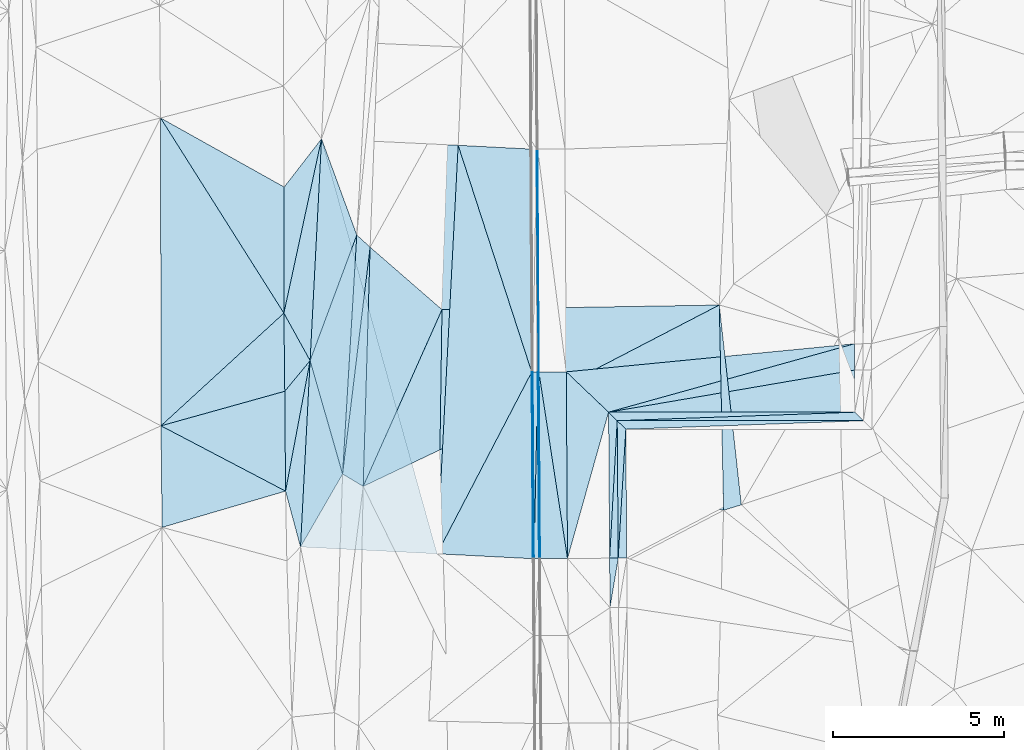
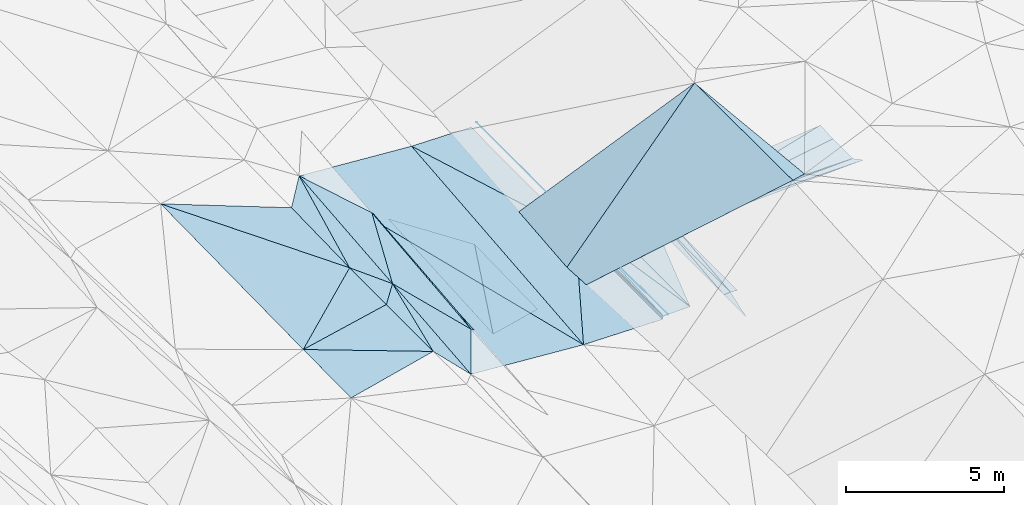
# One storey, part 93 of 275: 46 plates.
"""IFC2X3 building model written with IfcOpenShell, lengths in millimetres."""

from ifc_helpers import new_model, si_unit, frame, origin_with_axes, place, context, subcontext, project, spatial, polyline, outline, extrude, material, type_object, element, save


model = new_model("IFC2X3")

# Units and contexts
model_context = context("Model", 3, precision=1e-05, world=origin_with_axes())
body_context = subcontext(model_context, "Body", "Model", "MODEL_VIEW")
ifc_project = project(units=[si_unit("LENGTHUNIT", "METRE", prefix="MILLI"), si_unit("AREAUNIT", "SQUARE_METRE"), si_unit("VOLUMEUNIT", "CUBIC_METRE"), si_unit("MASSUNIT", "GRAM", prefix="KILO"), si_unit("TIMEUNIT", "SECOND"), si_unit("PLANEANGLEUNIT", "RADIAN"), si_unit("SOLIDANGLEUNIT", "STERADIAN"), si_unit("THERMODYNAMICTEMPERATUREUNIT", "DEGREE_CELSIUS"), si_unit("LUMINOUSINTENSITYUNIT", "LUMEN")], contexts=[model_context])

# Site, building, storey
site_placement = place(None, origin_with_axes())
site = spatial("IfcSite", under=ifc_project, at=site_placement, CompositionType="ELEMENT")
building_placement = place(site_placement, origin_with_axes())
building = spatial("IfcBuilding", under=site, at=building_placement, Name="Undefined", CompositionType="ELEMENT")
storey_placement = place(building_placement, origin_with_axes())
storey = spatial("IfcBuildingStorey", under=building, at=storey_placement, Name="Undefined", CompositionType="ELEMENT", Elevation=0.0)

# Plates
ifc_material = material()
plate_type_1 = type_object("IfcPlateType", PredefinedType="NOTDEFINED")
plate_1_placement = place(storey_placement, frame((-54754.6561920561, 44967.0363280039, 42200.3706993939), z_axis=(-0.050053988637223, 0.0171037844885867, -0.998600049458076), x_axis=(0.00717859700115731, -0.999821363627105, -0.0174845240121561)))
element("IfcPlate", 1, at=plate_1_placement, inside=storey, type_object=plate_type_1, material=ifc_material, Name="00_PR", context=body_context, shape_type="SweptSolid", body=[
    extrude(outline(polyline([(0.0, 0.0), (3767.44604492188, 6.30097929388285e-09), (3767.22729492188, 250.31266784668), (0.0, 0.0)])), frame((-8.85201319254618e-08, 2.18876761149539e-07, -0.5000001331573), z_axis=(0.0, 0.0, 1.0), x_axis=(1.0, 0.0, 0.0)), (0.0, 0.0, 1.0), 1.0),
])
plate_2_placement = place(storey_placement, frame((-54977.5969884626, 41198.4681318585, 42146.9983466235), z_axis=(-0.0335830980741986, 0.0161393565483661, -0.999305607256331), x_axis=(-0.0071784180017678, 0.999839918963378, 0.0163892270195271)))
element("IfcPlate", 2, at=plate_2_placement, inside=storey, type_object=plate_type_1, material=ifc_material, Name="00_PR", context=body_context, shape_type="SweptSolid", body=[
    extrude(outline(polyline([(0.0, 0.0), (4019.2255859375, 3.7325662560761e-09), (3767.23876953125, 250.139389038086), (0.0, 0.0)])), frame((-8.85201319254618e-08, 2.18876761149539e-07, -0.5000001331573), z_axis=(0.0, 0.0, 1.0), x_axis=(1.0, 0.0, 0.0)), (0.0, 0.0, 1.0), 1.0),
])
plate_3_placement = place(storey_placement, frame((-55006.4219450163, 45217.0504764407, 42212.8701665669), z_axis=(0.0198752310703333, 0.0165290688810968, -0.999665826700015), x_axis=(0.00717841802048257, -0.999839918963305, -0.0163892270158142)))
element("IfcPlate", 3, at=plate_3_placement, inside=storey, type_object=plate_type_1, material=ifc_material, Name="00_PR", context=body_context, shape_type="SweptSolid", body=[
    extrude(outline(polyline([(0.0, 0.0), (4019.2255859375, 3.7325662560761e-09), (4019.30688476563, 250.049514770508), (0.0, 0.0)])), frame((-8.85201319254618e-08, 2.18876761149539e-07, -0.5000001331573), z_axis=(0.0, 0.0, 1.0), x_axis=(1.0, 0.0, 0.0)), (0.0, 0.0, 1.0), 1.0),
])
plate_4_placement = place(storey_placement, frame((-55006.4256258741, 45217.0734608537, 42212.8710160335), z_axis=(0.0125132449151015, 0.0624980377927703, -0.997966639709839), x_axis=(0.999921442568018, -5.72289783641868e-05, 0.0125341699979891)))
element("IfcPlate", 4, at=plate_4_placement, inside=storey, type_object=plate_type_1, material=ifc_material, Name="00_PR", context=body_context, shape_type="SweptSolid", body=[
    extrude(outline(polyline([(0.0, 0.0), (7201.75341796875, -2.31520971283317e-08), (251.638565063477, 250.489715576172), (0.0, 0.0)])), frame((-8.85201319254618e-08, 2.18876761149539e-07, -0.5000001331573), z_axis=(0.0, 0.0, 1.0), x_axis=(1.0, 0.0, 0.0)), (0.0, 0.0, 1.0), 1.0),
])
plate_5_placement = place(storey_placement, frame((-48057.0388273613, 45466.6408138682, 42298.1380522502), z_axis=(0.0125334070268612, -0.0073737759030965, -0.999894264978668), x_axis=(0.709548887107373, -0.704515339074986, 0.0140894929910481)))
element("IfcPlate", 5, at=plate_5_placement, inside=storey, type_object=plate_type_1, material=ifc_material, Name="00_PR", context=body_context, shape_type="SweptSolid", body=[
    extrude(outline(polyline([(0.0, 0.0), (354.874359130859, -1.2801137927454e-10), (-4756.2822265625, 5073.59130859375), (0.0, 0.0)])), frame((-8.85201319254618e-08, 2.18876761149539e-07, -0.5000001331573), z_axis=(0.0, 0.0, 1.0), x_axis=(1.0, 0.0, 0.0)), (0.0, 0.0, 1.0), 1.0),
])
plate_6_placement = place(storey_placement, frame((-55217.1639350213, 39748.2080350099, 42122.2991473268), z_axis=(0.0198960001570522, 0.013738804213122, -0.999707654485322), x_axis=(-0.00717939200616372, 0.999881764103199, 0.0135983140240582)))
element("IfcPlate", 6, at=plate_6_placement, inside=storey, type_object=plate_type_1, material=ifc_material, Name="00_PR", context=body_context, shape_type="SweptSolid", body=[
    extrude(outline(polyline([(0.0, 0.0), (1448.63586425781, 2.10275175049901e-09), (1448.70336914063, 250.049514770508), (0.0, 0.0)])), frame((-8.85201319254618e-08, 2.18876761149539e-07, -0.5000001331573), z_axis=(0.0, 0.0, 1.0), x_axis=(1.0, 0.0, 0.0)), (0.0, 0.0, 1.0), 1.0),
])
plate_7_placement = place(storey_placement, frame((-55258.227644883, 45467.0534748413, 42207.8700538032), z_axis=(0.0125334070268612, -0.0073737759030965, -0.999894264978668), x_axis=(0.999921442568018, -5.72289783641868e-05, 0.0125341699979891)))
element("IfcPlate", 7, at=plate_7_placement, inside=storey, type_object=plate_type_1, material=ifc_material, Name="00_PR", context=body_context, shape_type="SweptSolid", body=[
    extrude(outline(polyline([(0.0, 0.0), (7201.75439453125, 1.70766725204885e-08), (251.859252929688, 250.007308959961), (0.0, 0.0)])), frame((-8.85201319254618e-08, 2.18876761149539e-07, -0.5000001331573), z_axis=(0.0, 0.0, 1.0), x_axis=(1.0, 0.0, 0.0)), (0.0, 0.0, 1.0), 1.0),
])
plate_8_placement = place(storey_placement, frame((-55227.555591409, 41196.6735691613, 42141.9983757898), z_axis=(0.0353986654577949, 0.0156678779979407, -0.999250445125169), x_axis=(-0.0071787759749593, 0.999855286850542, 0.0154230519846361)))
element("IfcPlate", 8, at=plate_8_placement, inside=storey, type_object=plate_type_1, material=ifc_material, Name="00_PR", context=body_context, shape_type="SweptSolid", body=[
    extrude(outline(polyline([(0.0, 0.0), (4271.00927734375, -1.06738298200071e-08), (4019.30029296875, 250.158294677734), (0.0, 0.0)])), frame((-8.85201319254618e-08, 2.18876761149539e-07, -0.5000001331573), z_axis=(0.0, 0.0, 1.0), x_axis=(1.0, 0.0, 0.0)), (0.0, 0.0, 1.0), 1.0),
])
plate_type_2 = type_object("IfcPlateType", PredefinedType="NOTDEFINED")
plate_9_placement = place(storey_placement, frame((-60131.2364615722, 48467.1082151592, 41398.51102448), z_axis=(-0.208831258783184, 0.00492731227025753, -0.977939275696003), x_axis=(-0.0144608824656281, -0.999893534677639, -0.00194992004242631)))
element("IfcPlate", 9, at=plate_9_placement, inside=storey, type_object=plate_type_2, material=ifc_material, Name="00", context=body_context, shape_type="SweptSolid", body=[
    extrude(outline(polyline([(0.0, 0.0), (4102.73291015625, 6.28642737865448e-09), (5202.06005859375, 2279.5048828125), (0.0, 0.0)])), frame((-8.85201319254618e-08, 2.18876761149539e-07, -0.5000001331573), z_axis=(0.0, 0.0, 1.0), x_axis=(1.0, 0.0, 0.0)), (0.0, 0.0, 1.0), 1.0),
])
plate_type_3 = type_object("IfcPlateType", PredefinedType="NOTDEFINED")
plate_10_placement = place(storey_placement, frame((-60273.6242718858, 41325.1492362148, 41896.5693542058), z_axis=(-0.0322864705022695, 0.019242341184966, -0.999293408428289), x_axis=(-0.998195226832826, 0.0500309300157187, 0.0332143819741704)))
element("IfcPlate", 10, at=plate_10_placement, inside=storey, type_object=plate_type_3, material=ifc_material, Name="00_PR", context=body_context, shape_type="SweptSolid", body=[
    extrude(outline(polyline([(0.0, 0.0), (4002.2119140625, -2.02999217435718e-09), (3992.19409179688, 11955.9609375), (0.0, 0.0)])), frame((-8.85201319254618e-08, 2.18876761149539e-07, -0.5000001331573), z_axis=(0.0, 0.0, 1.0), x_axis=(1.0, 0.0, 0.0)), (0.0, 0.0, 1.0), 1.0),
])
plate_type_4 = type_object("IfcPlateType", PredefinedType="NOTDEFINED")
plate_11_placement = place(storey_placement, frame((-57505.9185339254, 46640.2107482586, 42065.3517347379), z_axis=(0.970089214317012, 0.0102205203270063, -0.242533414667025), x_axis=(0.242518705990443, 0.00267351302670711, 0.970143045933339)))
element("IfcPlate", 11, at=plate_11_placement, inside=storey, type_object=plate_type_4, material=ifc_material, Name="00_PR", context=body_context, shape_type="SweptSolid", body=[
    extrude(outline(polyline([(0.0, 0.0), (123.693099975586, 3.20142135024071e-10), (36.241886138916, 5459.546875), (0.0, 0.0)])), frame((-8.85201319254618e-08, 2.18876761149539e-07, -0.5000001331573), z_axis=(0.0, 0.0, 1.0), x_axis=(1.0, 0.0, 0.0)), (0.0, 0.0, 1.0), 1.0),
])
plate_12_placement = place(storey_placement, frame((-57439.4557299682, 41181.0656523603, 42101.1387341122), z_axis=(0.970088817603844, 0.0102205056216197, -0.242535002061175), x_axis=(-0.242514674954377, -0.00320214202672689, -0.970142452796605)))
element("IfcPlate", 12, at=plate_12_placement, inside=storey, type_object=plate_type_4, material=ifc_material, Name="00_PR", context=body_context, shape_type="SweptSolid", body=[
    extrude(outline(polyline([(0.0, 0.0), (123.693176269531, -2.18278728425503e-11), (33.3557357788086, 5459.56494140625), (0.0, 0.0)])), frame((-8.85201319254618e-08, 2.18876761149539e-07, -0.5000001331573), z_axis=(0.0, 0.0, 1.0), x_axis=(1.0, 0.0, 0.0)), (0.0, 0.0, 1.0), 1.0),
])
plate_type_5 = type_object("IfcPlateType", PredefinedType="NOTDEFINED")
plate_13_placement = place(storey_placement, frame((-57439.9408222537, 41181.0682522599, 42100.7600627762), z_axis=(-9.13452244903414e-05, 0.0154229424386856, -0.999881055177356), x_axis=(0.0207857459866335, 0.999665067370755, 0.0154177119704065)))
element("IfcPlate", 13, at=plate_13_placement, inside=storey, type_object=plate_type_5, material=ifc_material, Name="00_PR", context=body_context, shape_type="SweptSolid", body=[
    extrude(outline(polyline([(0.0, 0.0), (5462.0947265625, 1.3526005204767e-08), (4.00590229034424, 149.946624755859), (0.0, 0.0)])), frame((-8.85201319254618e-08, 2.18876761149539e-07, -0.5000001331573), z_axis=(0.0, 0.0, 1.0), x_axis=(1.0, 0.0, 0.0)), (0.0, 0.0, 1.0), 1.0),
])
plate_14_placement = place(storey_placement, frame((-57326.4071096397, 46641.3334336562, 42184.9730626691), z_axis=(-8.11642197370288e-05, 0.0154227308238677, -0.999881059319709), x_axis=(-0.0207857459545196, -0.999665067371238, -0.0154177119823899)))
element("IfcPlate", 14, at=plate_14_placement, inside=storey, type_object=plate_type_5, material=ifc_material, Name="00_PR", context=body_context, shape_type="SweptSolid", body=[
    extrude(outline(polyline([(0.0, 0.0), (5462.0947265625, 1.3526005204767e-08), (3.90695929527283, 149.949813842773), (0.0, 0.0)])), frame((-8.85201319254618e-08, 2.18876761149539e-07, -0.5000001331573), z_axis=(0.0, 0.0, 1.0), x_axis=(1.0, 0.0, 0.0)), (0.0, 0.0, 1.0), 1.0),
])
plate_type_6 = type_object("IfcPlateType", PredefinedType="NOTDEFINED")
plate_15_placement = place(storey_placement, frame((-57333.3932535563, 53156.9671595904, 42286.7951616364), z_axis=(0.0199137889874449, 0.0156437858381664, -0.999679305063786), x_axis=(0.00567731103244658, -0.999863228802806, -0.0155335709824878)))
element("IfcPlate", 15, at=plate_15_placement, inside=storey, type_object=plate_type_6, material=ifc_material, Name="00_PR", context=body_context, shape_type="SweptSolid", body=[
    extrude(outline(polyline([(0.0, 0.0), (6516.337890625, -1.64873199537396e-08), (-0.00770944636315107, 30.0061664581299), (0.0, 0.0)])), frame((-8.85201319254618e-08, 2.18876761149539e-07, -0.5000001331573), z_axis=(0.0, 0.0, 1.0), x_axis=(1.0, 0.0, 0.0)), (0.0, 0.0, 1.0), 1.0),
])
plate_16_placement = place(storey_placement, frame((-57296.3979936511, 46641.5204184766, 42185.5731607943), z_axis=(0.0198831661735067, 0.0155533504782911, -0.999681325719259), x_axis=(0.00667819302977025, -0.999858752033622, -0.0154232849816642)))
element("IfcPlate", 16, at=plate_16_placement, inside=storey, type_object=plate_type_6, material=ifc_material, Name="00_PR", context=body_context, shape_type="SweptSolid", body=[
    extrude(outline(polyline([(0.0, 0.0), (5460.12060546875, 1.83354131877422e-08), (5460.14404296875, 30.0058403015137), (0.0, 0.0)])), frame((-8.85201319254618e-08, 2.18876761149539e-07, -0.5000001331573), z_axis=(0.0, 0.0, 1.0), x_axis=(1.0, 0.0, 0.0)), (0.0, 0.0, 1.0), 1.0),
])
plate_17_placement = place(storey_placement, frame((-57289.9333338589, 41181.9567086389, 42100.7601628065), z_axis=(0.0198972894556554, 0.0155533629643728, -0.999681044520109), x_axis=(-0.0066781930210375, 0.999858752033822, 0.0154232849724548)))
element("IfcPlate", 17, at=plate_17_placement, inside=storey, type_object=plate_type_6, material=ifc_material, Name="00_PR", context=body_context, shape_type="SweptSolid", body=[
    extrude(outline(polyline([(0.0, 0.0), (5460.14794921875, -1.5905243344605e-08), (5460.14404296875, 30.0057125091553), (0.0, 0.0)])), frame((-8.85201319254618e-08, 2.18876761149539e-07, -0.5000001331573), z_axis=(0.0, 0.0, 1.0), x_axis=(1.0, 0.0, 0.0)), (0.0, 0.0, 1.0), 1.0),
])
plate_type_7 = type_object("IfcPlateType", PredefinedType="NOTDEFINED")
plate_18_placement = place(storey_placement, frame((-63653.2273203775, 53463.653851786, 42239.5003682818), z_axis=(-0.0333468863461825, 0.0189462760226475, -0.999264241227459), x_axis=(0.998268639349457, -0.0478400050471519, -0.0342207189940953)))
element("IfcPlate", 18, at=plate_18_placement, inside=storey, type_object=plate_type_7, material=ifc_material, Name="00_PR", context=body_context, shape_type="SweptSolid", body=[
    extrude(outline(polyline([(0.0, 0.0), (4002.37060546875, -7.55971996113658e-09), (3966.19262695313, 11964.611328125), (0.0, 0.0)])), frame((-8.85201319254618e-08, 2.18876761149539e-07, -0.5000001331573), z_axis=(0.0, 0.0, 1.0), x_axis=(1.0, 0.0, 0.0)), (0.0, 0.0, 1.0), 1.0),
])
plate_type_8 = type_object("IfcPlateType", PredefinedType="NOTDEFINED")
plate_19_placement = place(storey_placement, frame((-48071.4047826636, 47466.6370522363, 42382.0769789326), z_axis=(-0.00058007674561187, 0.0888629904230633, -0.996043690027722), x_axis=(0.00715078199816748, -0.996018022971129, -0.0888648650114254)))
element("IfcPlate", 19, at=plate_19_placement, inside=storey, type_object=plate_type_8, material=ifc_material, Name="00_PR", context=body_context, shape_type="SweptSolid", body=[
    extrude(outline(polyline([(0.0, 0.0), (770.709533691406, -1.50612322613597e-09), (1955.66259765625, 7200.9990234375), (0.0, 0.0)])), frame((-8.85201319254618e-08, 2.18876761149539e-07, -0.5000001331573), z_axis=(0.0, 0.0, 1.0), x_axis=(1.0, 0.0, 0.0)), (0.0, 0.0, 1.0), 1.0),
])
plate_type_9 = type_object("IfcPlateType", PredefinedType="NOTDEFINED")
plate_20_placement = place(storey_placement, frame((-48065.8870492746, 46698.9583307277, 42313.5860800238), z_axis=(0.0125338923302833, 0.0126238441954289, -0.999841757530052), x_axis=(0.00717946097368381, -0.999895665081337, -0.0125345239908739)))
element("IfcPlate", 20, at=plate_20_placement, inside=storey, type_object=plate_type_9, material=ifc_material, Name="00_PR", context=body_context, shape_type="SweptSolid", body=[
    extrude(outline(polyline([(0.0, 0.0), (1232.43615722656, -4.04543243348598e-09), (1181.45434570313, 7201.57421875), (0.0, 0.0)])), frame((-8.85201319254618e-08, 2.18876761149539e-07, -0.5000001331573), z_axis=(0.0, 0.0, 1.0), x_axis=(1.0, 0.0, 0.0)), (0.0, 0.0, 1.0), 1.0),
])
plate_type_10 = type_object("IfcPlateType", PredefinedType="NOTDEFINED")
plate_21_placement = place(storey_placement, frame((-55258.2239739732, 45467.0649431578, 42207.8701604175), z_axis=(0.019903297863113, 0.015557512476293, -0.999680860344801), x_axis=(-0.724072856799147, 0.689713663845179, -0.00368238400789)))
element("IfcPlate", 21, at=plate_21_placement, inside=storey, type_object=plate_type_10, material=ifc_material, Name="00_PR", context=body_context, shape_type="SweptSolid", body=[
    extrude(outline(polyline([(0.0, 0.0), (1710.03344726563, -1.67710823006928e-09), (-3825.32275390625, 6406.70849609375), (0.0, 0.0)])), frame((-8.85201319254618e-08, 2.18876761149539e-07, -0.5000001331573), z_axis=(0.0, 0.0, 1.0), x_axis=(1.0, 0.0, 0.0)), (0.0, 0.0, 1.0), 1.0),
])
plate_type_11 = type_object("IfcPlateType", PredefinedType="NOTDEFINED")
plate_22_placement = place(storey_placement, frame((-56496.4127879231, 46646.4983941484, 42201.5731610095), z_axis=(0.019897195094357, 0.0155555039090625, -0.999681013086431), x_axis=(0.00667821399454487, -0.99985872005324, -0.0154253489860309)))
element("IfcPlate", 22, at=plate_22_placement, inside=storey, type_object=plate_type_11, material=ifc_material, Name="00_PR", context=body_context, shape_type="SweptSolid", body=[
    extrude(outline(polyline([(0.0, 0.0), (5459.39013671875, -1.72440195456147e-08), (-0.118396855890751, 800.16064453125), (0.0, 0.0)])), frame((-8.85201319254618e-08, 2.18876761149539e-07, -0.5000001331573), z_axis=(0.0, 0.0, 1.0), x_axis=(1.0, 0.0, 0.0)), (0.0, 0.0, 1.0), 1.0),
])
plate_23_placement = place(storey_placement, frame((-57259.9342531593, 41182.1709404201, 42101.3601609169), z_axis=(0.0198831661735067, 0.0155533504782911, -0.999681325719259), x_axis=(-0.0066781930210375, 0.999858752033822, 0.0154232849724548)))
element("IfcPlate", 23, at=plate_23_placement, inside=storey, type_object=plate_type_11, material=ifc_material, Name="00_PR", context=body_context, shape_type="SweptSolid", body=[
    extrude(outline(polyline([(0.0, 0.0), (5460.12060546875, 1.83354131877422e-08), (0.611967802047729, 800.160522460938), (0.0, 0.0)])), frame((-8.85201319254618e-08, 2.18876761149539e-07, -0.5000001331573), z_axis=(0.0, 0.0, 1.0), x_axis=(1.0, 0.0, 0.0)), (0.0, 0.0, 1.0), 1.0),
])
plate_type_12 = type_object("IfcPlateType", PredefinedType="NOTDEFINED")
plate_24_placement = place(storey_placement, frame((-56459.9538061074, 41187.8793675708, 42117.3601610179), z_axis=(0.0199014105104961, 0.0155555307619156, -0.999680928757975), x_axis=(-0.00667821399304553, 0.999858720053274, 0.0154253489844649)))
element("IfcPlate", 24, at=plate_24_placement, inside=storey, type_object=plate_type_12, material=ifc_material, Name="00_PR", context=body_context, shape_type="SweptSolid", body=[
    extrude(outline(polyline([(0.0, 0.0), (5459.39013671875, -1.72440195456147e-08), (4271.95166015625, 1230.53002929688), (0.0, 0.0)])), frame((-8.85201319254618e-08, 2.18876761149539e-07, -0.5000001331573), z_axis=(0.0, 0.0, 1.0), x_axis=(1.0, 0.0, 0.0)), (0.0, 0.0, 1.0), 1.0),
])
plate_type_13 = type_object("IfcPlateType", PredefinedType="NOTDEFINED")
plate_25_placement = place(storey_placement, frame((-59657.754018102, 53272.1788114362, 42102.5363037553), z_axis=(0.0310161038302799, 0.0157219267080249, -0.999395228287476), x_axis=(0.998218742855814, -0.0514695879700982, 0.0301699009866757)))
element("IfcPlate", 25, at=plate_25_placement, inside=storey, type_object=plate_type_13, material=ifc_material, Name="00_PR", context=body_context, shape_type="SweptSolid", body=[
    extrude(outline(polyline([(0.0, 0.0), (2118.1044921875, -6.38829078525305e-09), (2487.7451171875, 6513.361328125), (0.0, 0.0)])), frame((-8.85201319254618e-08, 2.18876761149539e-07, -0.5000001331573), z_axis=(0.0, 0.0, 1.0), x_axis=(1.0, 0.0, 0.0)), (0.0, 0.0, 1.0), 1.0),
])
plate_type_14 = type_object("IfcPlateType", PredefinedType="NOTDEFINED")
plate_26_placement = place(storey_placement, frame((-57506.3881912908, 46640.2134596803, 42064.9732996112), z_axis=(0.0307739461009114, 0.015643421975049, -0.999403946155051), x_axis=(-0.461613138973683, -0.886636410996624, -0.0280924299748123)))
element("IfcPlate", 26, at=plate_26_placement, inside=storey, type_object=plate_type_14, material=ifc_material, Name="00_PR", context=body_context, shape_type="SweptSolid", body=[
    extrude(outline(polyline([(0.0, 0.0), (5994.64013671875, -1.00699253380299e-08), (-4888.09814453125, 4971.84521484375), (0.0, 0.0)])), frame((-8.85201319254618e-08, 2.18876761149539e-07, -0.5000001331573), z_axis=(0.0, 0.0, 1.0), x_axis=(1.0, 0.0, 0.0)), (0.0, 0.0, 1.0), 1.0),
])
plate_type_15 = type_object("IfcPlateType", PredefinedType="NOTDEFINED")
plate_27_placement = place(storey_placement, frame((-60273.5927210615, 41325.1474282784, 41896.5693001057), z_axis=(0.0308159180927162, 0.0156215397920913, -0.99940299513591), x_axis=(0.461613138971989, 0.886636410997533, 0.0280924299739359)))
element("IfcPlate", 27, at=plate_27_placement, inside=storey, type_object=plate_type_15, material=ifc_material, Name="00_PR", context=body_context, shape_type="SweptSolid", body=[
    extrude(outline(polyline([(0.0, 0.0), (5994.64013671875, -1.00699253380299e-08), (1168.47912597656, 2554.05224609375), (0.0, 0.0)])), frame((-8.85201319254618e-08, 2.18876761149539e-07, -0.5000001331573), z_axis=(0.0, 0.0, 1.0), x_axis=(1.0, 0.0, 0.0)), (0.0, 0.0, 1.0), 1.0),
])
plate_type_16 = type_object("IfcPlateType", PredefinedType="NOTDEFINED")
plate_28_placement = place(storey_placement, frame((-63987.8271258391, 46974.2046263685, 42129.5001655714), z_axis=(-0.0205081433501414, 0.0169567398640997, -0.999645879814203), x_axis=(-0.184939913394449, -0.982665494161713, -0.0128745880543849)))
element("IfcPlate", 28, at=plate_28_placement, inside=storey, type_object=plate_type_16, material=ifc_material, Name="00", context=body_context, shape_type="SweptSolid", body=[
    extrude(outline(polyline([(0.0, 0.0), (3883.61938476563, -4.8748916015029e-09), (1017.607421875, 562.561218261719), (0.0, 0.0)])), frame((-8.85201319254618e-08, 2.18876761149539e-07, -0.5000001331573), z_axis=(0.0, 0.0, 1.0), x_axis=(1.0, 0.0, 0.0)), (0.0, 0.0, 1.0), 1.0),
])
plate_type_17 = type_object("IfcPlateType", PredefinedType="NOTDEFINED")
plate_29_placement = place(storey_placement, frame((-63653.2293928129, 53463.6552904736, 42239.5004547855), z_axis=(-0.0372834350168629, 0.0217611188936698, -0.999067765057926), x_axis=(-0.211057515330362, -0.977381619847664, -0.0134124720514585)))
element("IfcPlate", 29, at=plate_29_placement, inside=storey, type_object=plate_type_17, material=ifc_material, Name="00", context=body_context, shape_type="SweptSolid", body=[
    extrude(outline(polyline([(0.0, 0.0), (5219.02294921875, -1.6778358258307e-08), (1610.68469238281, 770.191528320313), (0.0, 0.0)])), frame((-8.85201319254618e-08, 2.18876761149539e-07, -0.5000001331573), z_axis=(0.0, 0.0, 1.0), x_axis=(1.0, 0.0, 0.0)), (0.0, 0.0, 1.0), 1.0),
])
plate_type_18 = type_object("IfcPlateType", PredefinedType="NOTDEFINED")
plate_30_placement = place(storey_placement, frame((-60131.2600685729, 48467.1192607718, 41398.5168505013), z_axis=(-0.256044144124866, 0.0270191226725977, -0.966287412351712), x_axis=(-0.405704359347007, -0.910314249796572, 0.0820483968407598)))
element("IfcPlate", 30, at=plate_30_placement, inside=storey, type_object=plate_type_18, material=ifc_material, Name="00", context=body_context, shape_type="SweptSolid", body=[
    extrude(outline(polyline([(0.0, 0.0), (5679.57470703125, -1.23691279441118e-08), (-759.683654785156, 2746.78002929688), (0.0, 0.0)])), frame((-8.85201319254618e-08, 2.18876761149539e-07, -0.5000001331573), z_axis=(0.0, 0.0, 1.0), x_axis=(1.0, 0.0, 0.0)), (0.0, 0.0, 1.0), 1.0),
])
plate_type_19 = type_object("IfcPlateType", PredefinedType="NOTDEFINED")
plate_31_placement = place(storey_placement, frame((-62622.6891740049, 50647.8969159883, 42160.5001954463), z_axis=(-0.0229115930090386, 0.0169488664964395, -0.999593814921978), x_axis=(-0.0592883314823341, -0.998119545343259, -0.0155649270415063)))
element("IfcPlate", 31, at=plate_31_placement, inside=storey, type_object=plate_type_19, material=ifc_material, Name="00", context=body_context, shape_type="SweptSolid", body=[
    extrude(outline(polyline([(0.0, 0.0), (7002.923828125, 1.04773789644241e-09), (3748.20336914063, 1145.23010253906), (0.0, 0.0)])), frame((-8.85201319254618e-08, 2.18876761149539e-07, -0.5000001331573), z_axis=(0.0, 0.0, 1.0), x_axis=(1.0, 0.0, 0.0)), (0.0, 0.0, 1.0), 1.0),
])
plate_type_20 = type_object("IfcPlateType", PredefinedType="NOTDEFINED")
plate_32_placement = place(storey_placement, frame((-63653.2240459974, 53463.6535640847, 42239.5002529894), z_axis=(-0.0265837321675006, 0.0183124588276819, -0.999478843715929), x_axis=(0.34357360547505, -0.938756347741967, -0.0263381319580016)))
element("IfcPlate", 32, at=plate_32_placement, inside=storey, type_object=plate_type_20, material=ifc_material, Name="00", context=body_context, shape_type="SweptSolid", body=[
    extrude(outline(polyline([(0.0, 0.0), (2999.45336914063, 6.9339876063168e-09), (5979.9462890625, 2545.04321289063), (0.0, 0.0)])), frame((-8.85201319254618e-08, 2.18876761149539e-07, -0.5000001331573), z_axis=(0.0, 0.0, 1.0), x_axis=(1.0, 0.0, 0.0)), (0.0, 0.0, 1.0), 1.0),
])
plate_type_21 = type_object("IfcPlateType", PredefinedType="NOTDEFINED")
plate_33_placement = place(storey_placement, frame((-63987.8360630767, 46974.2063044668, 42129.5004601719), z_axis=(-0.0383834512540743, 0.0203131928575153, -0.999056597428674), x_axis=(-0.0514535353943072, -0.998507246322793, -0.0183251940316938)))
element("IfcPlate", 33, at=plate_33_placement, inside=storey, type_object=plate_type_21, material=ifc_material, Name="00", context=body_context, shape_type="SweptSolid", body=[
    extrude(outline(polyline([(0.0, 0.0), (5456.96826171875, -1.17870513349772e-08), (3848.47412109375, 521.293823242188), (0.0, 0.0)])), frame((-8.85201319254618e-08, 2.18876761149539e-07, -0.5000001331573), z_axis=(0.0, 0.0, 1.0), x_axis=(1.0, 0.0, 0.0)), (0.0, 0.0, 1.0), 1.0),
])
plate_type_22 = type_object("IfcPlateType", PredefinedType="NOTDEFINED")
plate_34_placement = place(storey_placement, frame((-63653.2205657407, 53463.653388336, 42239.500165661), z_axis=(-0.0196288233764554, 0.0179566870940788, -0.999646070707759), x_axis=(-0.0514857863485739, -0.998530287535762, -0.0169256810149085)))
element("IfcPlate", 34, at=plate_34_placement, inside=storey, type_object=plate_type_22, material=ifc_material, Name="00", context=body_context, shape_type="SweptSolid", body=[
    extrude(outline(polyline([(0.0, 0.0), (6499.0, -1.68656697496772e-08), (5151.376953125, 837.563720703125), (0.0, 0.0)])), frame((-8.85201319254618e-08, 2.18876761149539e-07, -0.5000001331573), z_axis=(0.0, 0.0, 1.0), x_axis=(1.0, 0.0, 0.0)), (0.0, 0.0, 1.0), 1.0),
])
plate_type_23 = type_object("IfcPlateType", PredefinedType="NOTDEFINED")
plate_35_placement = place(storey_placement, frame((-63987.8245251216, 46974.2057128975, 42129.5001395064), z_axis=(-0.0152891869231709, 0.0191349432157854, -0.999700002356385), x_axis=(0.275320995630337, -0.961086517006396, -0.0226065520067723)))
element("IfcPlate", 35, at=plate_35_placement, inside=storey, type_object=plate_type_23, material=ifc_material, Name="00", context=body_context, shape_type="SweptSolid", body=[
    extrude(outline(polyline([(0.0, 0.0), (3450.3271484375, -1.18961906991899e-08), (5161.74560546875, 1770.56042480469), (0.0, 0.0)])), frame((-8.85201319254618e-08, 2.18876761149539e-07, -0.5000001331573), z_axis=(0.0, 0.0, 1.0), x_axis=(1.0, 0.0, 0.0)), (0.0, 0.0, 1.0), 1.0),
])
plate_type_24 = type_object("IfcPlateType", PredefinedType="NOTDEFINED")
plate_36_placement = place(storey_placement, frame((-64728.7713317367, 46078.0915826198, 42129.5005311303), z_axis=(-0.0433672680436388, 0.0169965782397606, -0.998914609158646), x_axis=(-0.962539503708967, -0.26857495356385, 0.0372182497959095)))
element("IfcPlate", 36, at=plate_36_placement, inside=storey, type_object=plate_type_24, material=ifc_material, Name="00", context=body_context, shape_type="SweptSolid", body=[
    extrude(outline(polyline([(0.0, 0.0), (3761.59545898438, 7.07950675860047e-09), (-587.09130859375, 2208.37573242188), (0.0, 0.0)])), frame((-8.85201319254618e-08, 2.18876761149539e-07, -0.5000001331573), z_axis=(0.0, 0.0, 1.0), x_axis=(1.0, 0.0, 0.0)), (0.0, 0.0, 1.0), 1.0),
])
plate_type_25 = type_object("IfcPlateType", PredefinedType="NOTDEFINED")
plate_37_placement = place(storey_placement, frame((-62435.500855635, 43296.9217631434, 41864.5203602649), z_axis=(-0.281174911596404, 0.0276034603930396, -0.959259463369053), x_axis=(-0.828807092118039, 0.49689892246479, 0.257235815757003)))
element("IfcPlate", 37, at=plate_37_placement, inside=storey, type_object=plate_type_25, material=ifc_material, Name="00", context=body_context, shape_type="SweptSolid", body=[
    extrude(outline(polyline([(0.0, 0.0), (726.959411621094, 4.02906152885407e-10), (3345.22387695313, 6149.66064453125), (0.0, 0.0)])), frame((-8.85201319254618e-08, 2.18876761149539e-07, -0.5000001331573), z_axis=(0.0, 0.0, 1.0), x_axis=(1.0, 0.0, 0.0)), (0.0, 0.0, 1.0), 1.0),
])
plate_type_26 = type_object("IfcPlateType", PredefinedType="NOTDEFINED")
plate_38_placement = place(storey_placement, frame((-51894.8121510542, 42598.2783111021, 44540.5012870117), z_axis=(-0.067377152556517, 0.0253386470772251, -0.997405771127113), x_axis=(-0.0209611686243008, 0.999420871096889, 0.0268058170149608)))
element("IfcPlate", 38, at=plate_38_placement, inside=storey, type_object=plate_type_26, material=ifc_material, Name="00", context=body_context, shape_type="SweptSolid", body=[
    extrude(outline(polyline([(0.0, 0.0), (6006.1591796875, 2.17114575207233e-08), (147.607315063477, 523.24951171875), (0.0, 0.0)])), frame((-8.85201319254618e-08, 2.18876761149539e-07, -0.5000001331573), z_axis=(0.0, 0.0, 1.0), x_axis=(1.0, 0.0, 0.0)), (0.0, 0.0, 1.0), 1.0),
])
plate_type_27 = type_object("IfcPlateType", PredefinedType="NOTDEFINED")
plate_39_placement = place(storey_placement, frame((-64754.7449201978, 48362.6782399519, 42169.5005137427), z_axis=(-0.0403294043656748, 0.0217662077983493, -0.99894933372098), x_axis=(-0.533632048311866, 0.844772627312639, 0.0399505338860799)))
element("IfcPlate", 39, at=plate_39_placement, inside=storey, type_object=plate_type_27, material=ifc_material, Name="00", context=body_context, shape_type="SweptSolid", body=[
    extrude(outline(polyline([(0.0, 0.0), (6758.35791015625, 4.91127138957381e-09), (3114.39575195313, 1978.34265136719), (0.0, 0.0)])), frame((-8.85201319254618e-08, 2.18876761149539e-07, -0.5000001331573), z_axis=(0.0, 0.0, 1.0), x_axis=(1.0, 0.0, 0.0)), (0.0, 0.0, 1.0), 1.0),
])
plate_type_28 = type_object("IfcPlateType", PredefinedType="NOTDEFINED")
plate_40_placement = place(storey_placement, frame((-64754.7351957889, 48362.6759893882, 42169.5001718844), z_axis=(-0.0208807477785945, 0.0172648200048166, -0.999632892797355), x_axis=(0.483336772507556, -0.875071447624611, -0.0252096389134645)))
element("IfcPlate", 40, at=plate_40_placement, inside=storey, type_object=plate_type_28, material=ifc_material, Name="00", context=body_context, shape_type="SweptSolid", body=[
    extrude(outline(polyline([(0.0, 0.0), (1586.69470214844, 2.8521753847599e-09), (2012.73754882813, 1081.890625), (0.0, 0.0)])), frame((-8.85201319254618e-08, 2.18876761149539e-07, -0.5000001331573), z_axis=(0.0, 0.0, 1.0), x_axis=(1.0, 0.0, 0.0)), (0.0, 0.0, 1.0), 1.0),
])
plate_type_29 = type_object("IfcPlateType", PredefinedType="NOTDEFINED")
plate_41_placement = place(storey_placement, frame((-64706.0747666988, 43157.905709691, 42079.5005277125), z_axis=(-0.0433035117057139, 0.0167671602183701, -0.998921252257737), x_axis=(-0.884740602308157, 0.463794448456877, 0.0461386628326004)))
element("IfcPlate", 41, at=plate_41_placement, inside=storey, type_object=plate_type_29, material=ifc_material, Name="00", context=body_context, shape_type="SweptSolid", body=[
    extrude(outline(polyline([(0.0, 0.0), (4118.021484375, 1.29657564684749e-08), (1376.75341796875, 2575.85913085938), (0.0, 0.0)])), frame((-8.85201319254618e-08, 2.18876761149539e-07, -0.5000001331573), z_axis=(0.0, 0.0, 1.0), x_axis=(1.0, 0.0, 0.0)), (0.0, 0.0, 1.0), 1.0),
])
plate_type_30 = type_object("IfcPlateType", PredefinedType="NOTDEFINED")
plate_42_placement = place(storey_placement, frame((-68315.6852902233, 42097.8664566409, 42189.5005282973), z_axis=(-0.0382155561576411, 0.0264727694914535, -0.998918797371946), x_axis=(-0.0113648746252972, 0.999572853788192, 0.0269248880123958)))
element("IfcPlate", 42, at=plate_42_placement, inside=storey, type_object=plate_type_30, material=ifc_material, Name="00", context=body_context, shape_type="SweptSolid", body=[
    extrude(outline(polyline([(0.0, 0.0), (2971.22875976563, 6.54836185276508e-10), (1015.60675048828, 3624.03686523438), (0.0, 0.0)])), frame((-8.85201319254618e-08, 2.18876761149539e-07, -0.5000001331573), z_axis=(0.0, 0.0, 1.0), x_axis=(1.0, 0.0, 0.0)), (0.0, 0.0, 1.0), 1.0),
])
plate_type_31 = type_object("IfcPlateType", PredefinedType="NOTDEFINED")
plate_43_placement = place(storey_placement, frame((-68349.456331478, 45067.8221725667, 42269.5005828655), z_axis=(-0.0450163337997678, 0.0187989140944186, -0.998809356444011), x_axis=(-0.00130663762961226, 0.999820962701873, 0.0188768440160065)))
element("IfcPlate", 43, at=plate_43_placement, inside=storey, type_object=plate_type_31, material=ifc_material, Name="00", context=body_context, shape_type="SweptSolid", body=[
    extrude(outline(polyline([(0.0, 0.0), (9005.7421875, -2.11002770811319e-09), (3287.67993164063, 3602.66015625), (0.0, 0.0)])), frame((-8.85201319254618e-08, 2.18876761149539e-07, -0.5000001331573), z_axis=(0.0, 0.0, 1.0), x_axis=(1.0, 0.0, 0.0)), (0.0, 0.0, 1.0), 1.0),
])
plate_type_32 = type_object("IfcPlateType", PredefinedType="NOTDEFINED")
plate_44_placement = place(storey_placement, frame((-63038.0392453654, 43658.1507319342, 42051.5300471046), z_axis=(-0.339707604352882, 0.0348354567366414, -0.939885756088885), x_axis=(0.0592883315042806, 0.99811954534266, 0.0155649269962958)))
element("IfcPlate", 44, at=plate_44_placement, inside=storey, type_object=plate_type_32, material=ifc_material, Name="00", context=body_context, shape_type="SweptSolid", body=[
    extrude(outline(polyline([(0.0, 0.0), (7002.923828125, 1.04773789644241e-09), (6669.58349609375, 436.226013183594), (0.0, 0.0)])), frame((-8.85201319254618e-08, 2.18876761149539e-07, -0.5000001331573), z_axis=(0.0, 0.0, 1.0), x_axis=(1.0, 0.0, 0.0)), (0.0, 0.0, 1.0), 1.0),
])
plate_type_33 = type_object("IfcPlateType", PredefinedType="NOTDEFINED")
plate_45_placement = place(storey_placement, frame((-60190.272579843, 44364.8078633489, 41390.5369342958), z_axis=(0.377222587085213, -0.00364950902112201, -0.926115436042745), x_axis=(0.0144608824392676, 0.999893534678105, 0.00194991999919866)))
element("IfcPlate", 45, at=plate_45_placement, inside=storey, type_object=plate_type_33, material=ifc_material, Name="00", context=body_context, shape_type="SweptSolid", body=[
    extrude(outline(polyline([(0.0, 0.0), (4102.73291015625, 6.28642737865448e-09), (4360.2841796875, 8754.4794921875), (0.0, 0.0)])), frame((-8.85201319254618e-08, 2.18876761149539e-07, -0.5000001331573), z_axis=(0.0, 0.0, 1.0), x_axis=(1.0, 0.0, 0.0)), (0.0, 0.0, 1.0), 1.0),
])
plate_type_34 = type_object("IfcPlateType", PredefinedType="NOTDEFINED")
plate_46_placement = place(storey_placement, frame((-52020.494195428, 48600.9625876247, 44701.5339662232), z_axis=(0.360850817630914, 0.0325672046043223, -0.932054754077979), x_axis=(0.0209611686011518, -0.999420871097924, -0.0268058169944818)))
element("IfcPlate", 46, at=plate_46_placement, inside=storey, type_object=plate_type_34, material=ifc_material, Name="00", context=body_context, shape_type="SweptSolid", body=[
    extrude(outline(polyline([(0.0, 0.0), (6006.1591796875, 2.17114575207233e-08), (4151.18896484375, 8855.5419921875), (0.0, 0.0)])), frame((-8.85201319254618e-08, 2.18876761149539e-07, -0.5000001331573), z_axis=(0.0, 0.0, 1.0), x_axis=(1.0, 0.0, 0.0)), (0.0, 0.0, 1.0), 1.0),
])

save(model, "model.ifc")
